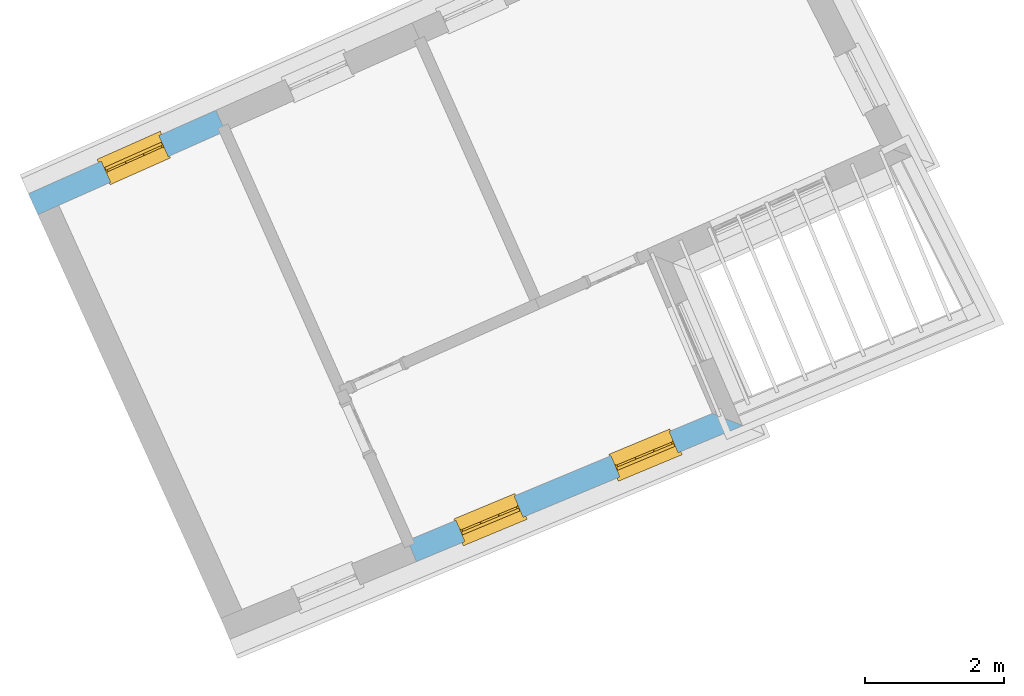
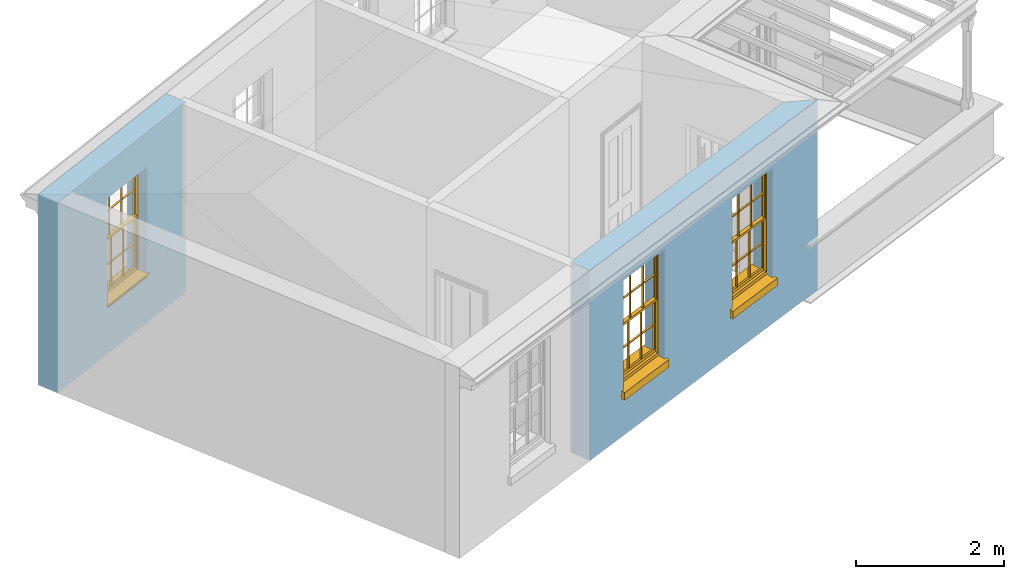
# One storey, part 3 of 10: 3 windows, 3 openings, plus 2 elements that do not belong to this part.
"""IFC2X3 building model written with IfcOpenShell, lengths in metres."""

from ifc_helpers import new_model, si_unit, frame, origin, place, context, subcontext, project, spatial, polyline, outline, extrude, faceted_brep, material, layer, layer_set, layer_usage, element, fill, save


model = new_model("IFC2X3")

# Units and contexts
model_context = context("Model", 3, world=origin())
body_context = subcontext(model_context, "Body", "Model", "MODEL_VIEW")
ifc_project = project(units=[si_unit("PLANEANGLEUNIT", "RADIAN"), si_unit("MASSUNIT", "GRAM", prefix="KILO"), si_unit("FORCEUNIT", "NEWTON", prefix="KILO"), si_unit("LENGTHUNIT", "METRE")], contexts=[model_context])

# Site, building, storey
site_placement = place(None, origin())
site = spatial("IfcSite", under=ifc_project, at=site_placement, CompositionType="ELEMENT")
building_placement = place(None, origin())
building = spatial("IfcBuilding", under=site, at=building_placement, Name="Building plot-1", CompositionType="ELEMENT")
storey_placement = place(None, frame((0.0, 0.0, 8.45)))
storey = spatial("IfcBuildingStorey", under=building, at=storey_placement, Name="Floor 2", CompositionType="ELEMENT", Elevation=8.45)

# Wall, openings, windows
ifc_material = material(Name="Masonry")
ifc_layer = layer(ifc_material, 0.33, ventilated=False)
ifc_layer_set = layer_set([ifc_layer], Name="My Wall")
ifc_layer_usage = layer_usage(ifc_layer_set, "AXIS2", "NEGATIVE", 0.08)
wall_1_placement = place(storey_placement, origin())
wall_1 = element("IfcWallStandardCase", 1, at=wall_1_placement, inside=storey, material=ifc_layer_usage, Name="exterior", context=body_context, shape_type="SweptSolid", body=[
    extrude(outline(polyline([(24.2430798056257, 41.3933128508107), (24.3699915253352, 41.0886927342715), (29.0644458342875, 43.0445099541443), (28.6286616795671, 43.2204467376737), (24.2430798056257, 41.3933128508107)])), origin(), (0.0, 0.0, 1.0), 3.15),
])
opening_1_placement = place(storey_placement, frame((0.0, 0.0, 0.75)))
opening_1 = element("IfcOpeningElement", 2, at=opening_1_placement, cuts=wall_1, Name="Opening", ObjectType="Opening", context=body_context, shape_type="SweptSolid", body=[
    extrude(outline(polyline([(25.0651000110172, 41.378290855055), (25.9051130596556, 41.7282595366783), (25.7782013399461, 42.0328796532175), (24.9381882913076, 41.6829109715942), (25.0651000110172, 41.378290855055)])), origin(), (0.0, 0.0, 1.0), 1.82),
])
opening_2_placement = place(storey_placement, frame((0.0, 0.0, 0.75)))
opening_2 = element("IfcOpeningElement", 3, at=opening_2_placement, cuts=wall_1, Name="Opening", ObjectType="Opening", context=body_context, shape_type="SweptSolid", body=[
    extrude(outline(polyline([(27.2953300310195, 42.3074557782452), (28.135343079658, 42.6574244598685), (28.0084313599484, 42.9620445764077), (27.16841831131, 42.6120758947844), (27.2953300310195, 42.3074557782452)])), origin(), (0.0, 0.0, 1.0), 1.82),
])
window_1_placement = place(storey_placement, frame((24.968954768813, 41.609063670615, 0.75), z_axis=(0.0, 0.0, 1.0), x_axis=(0.84001304863844, 0.349968681623302, 0.0)))
window_1 = element("IfcWindow", 4, at=window_1_placement, inside=storey, Name="circulation outside window", OverallHeight=1.82, OverallWidth=0.91, context=body_context, shape_type="Brep", held_by="IfcProductRepresentation", body=[
    faceted_brep([(0.033125, -0.105, 0.975209), (0.01, -0.105, 0.975209), (0.033125, -0.105, 1.376042), (0.876875, -0.105, 0.975209), (0.876875, -0.105, 1.376042), (0.9, -0.105, 0.975209), (0.876875, -0.105, 1.386042), (0.876875, -0.105, 1.786875), (0.9, -0.105, 1.81), (0.033125, -0.105, 1.786875), (0.033125, -0.105, 1.386042), (0.01, -0.105, 1.81), (0.876875, -0.135, 1.376042), (0.876875, -0.135, 0.975209), (0.9, -0.135, 0.937083), (0.033125, -0.135, 1.786875), (0.01, -0.135, 1.81), (0.033125, -0.135, 1.386042), (0.01, -0.135, 0.937083), (0.033125, -0.135, 0.975209), (0.033125, -0.135, 1.376042), (0.876875, -0.135, 1.786875), (0.876875, -0.135, 1.386042), (0.9, -0.135, 1.81), (0.033125, -0.105, 0.937083), (0.01, -0.105, 0.937083), (0.033125, -0.105, 0.53625), (0.876875, -0.105, 0.937083), (0.876875, -0.105, 0.53625), (0.9, -0.105, 0.937083), (0.876875, -0.105, 0.52625), (0.876875, -0.105, 0.125417), (0.9, -0.105, 0.077167), (0.033125, -0.105, 0.125417), (0.033125, -0.105, 0.52625), (0.01, -0.105, 0.077167), (-0.0425, -0.25, 0.01), (-0.0425, -0.3, 0.001667), (0.0, -0.25, 0.01), (0.9525, -0.25, 0.01), (0.91, -0.25, 0.01), (0.9525, -0.3, 0.001667), (-0.02, 0.08, 0.077167), (0.0, 0.08, 0.077167), (-0.02, 0.11, 0.077167), (0.0, -0.06, 0.077167), (0.01, -0.06, 0.077167), (0.91, -0.06, 0.077167), (0.91, 0.08, 0.077167), (0.9, -0.06, 0.077167), (0.93, 0.08, 0.077167), (0.93, 0.11, 0.077167), (0.01, -0.075, 0.975209), (0.9, -0.075, 0.975209), (0.876875, -0.075, 0.125417), (0.876875, -0.075, 0.52625), (0.9, -0.075, 0.077167), (0.876875, -0.075, 0.53625), (0.876875, -0.075, 0.937083), (0.033125, -0.075, 0.125417), (0.01, -0.075, 0.077167), (0.033125, -0.075, 0.52625), (0.033125, -0.075, 0.937083), (0.033125, -0.075, 0.53625), (-0.02, 0.08, 0.052167), (-0.02, 0.11, 0.052167), (0.93, 0.11, 0.052167), (0.93, 0.08, 0.052167), (0.91, 0.08, 0.052167), (0.0, 0.08, 0.052167), (0.91, -0.15, 0.026667), (0.0, -0.15, 0.026667), (-0.0425, -0.3, -0.123333), (0.9525, -0.3, -0.123333), (-0.0425, -0.25, -0.123333), (0.9525, -0.25, -0.123333), (0.01, -0.06, 1.81), (0.9, -0.06, 1.81), (0.0, -0.06, 1.82), (0.91, -0.06, 1.82), (0.01, -0.15, 0.077167), (0.9, -0.15, 0.077167), (0.592292, -0.105, 0.125417), (0.592292, -0.075, 0.125417), (0.317708, -0.075, 0.125417), (0.317708, -0.105, 0.125417), (0.592292, -0.105, 0.53625), (0.317708, -0.105, 0.53625), (0.317708, -0.105, 0.52625), (0.592292, -0.105, 0.52625), (0.592292, -0.075, 0.53625), (0.317708, -0.075, 0.53625), (0.592292, -0.135, 1.386042), (0.592292, -0.105, 1.386042), (0.317708, -0.105, 1.386042), (0.317708, -0.135, 1.386042), (0.317708, -0.135, 1.376042), (0.592292, -0.135, 1.376042), (0.317708, -0.105, 1.376042), (0.592292, -0.105, 1.376042), (0.602292, -0.135, 1.376042), (0.592292, -0.135, 0.975209), (0.602292, -0.135, 0.975209), (0.602292, -0.105, 0.975209), (0.592292, -0.105, 0.975209), (0.602292, -0.105, 1.376042), (0.602292, -0.075, 0.53625), (0.602292, -0.105, 0.53625), (0.317708, -0.075, 0.52625), (0.307708, -0.075, 0.125417), (0.307708, -0.075, 0.52625), (0.602292, -0.075, 0.52625), (0.602292, -0.075, 0.125417), (0.592292, -0.075, 0.52625), (0.307708, -0.075, 0.53625), (0.317708, -0.075, 0.937083), (0.307708, -0.075, 0.937083), (0.602292, -0.075, 0.937083), (0.592292, -0.075, 0.937083), (0.307708, -0.105, 0.52625), (0.307708, -0.105, 0.125417), (0.307708, -0.105, 0.53625), (0.307708, -0.105, 0.937083), (0.592292, -0.105, 0.937083), (0.317708, -0.105, 0.937083), (0.602292, -0.105, 0.937083), (0.602292, -0.105, 0.52625), (0.602292, -0.105, 0.125417), (0.307708, -0.135, 1.386042), (0.307708, -0.135, 1.376042), (0.307708, -0.135, 0.975209), (0.317708, -0.135, 0.975209), (0.317708, -0.135, 1.786875), (0.307708, -0.135, 1.786875), (0.602292, -0.135, 1.786875), (0.592292, -0.135, 1.786875), (0.602292, -0.135, 1.386042), (0.602292, -0.105, 1.386042), (0.307708, -0.105, 1.386042), (0.307708, -0.105, 1.786875), (0.317708, -0.105, 1.786875), (0.592292, -0.105, 1.786875), (0.602292, -0.105, 1.786875), (0.307708, -0.105, 1.376042), (0.317708, -0.105, 0.975209), (0.307708, -0.105, 0.975209), (0.91, -0.15, 1.82), (0.9, -0.15, 1.81), (0.01, -0.15, 1.81), (0.0, -0.15, 1.82), (0.91, -0.25, 0.0), (0.0, -0.25, 0.0), (0.91, 0.08, 0.0), (0.0, 0.08, 0.0)], [[[0, 1, 2]], [[3, 4, 5]], [[6, 7, 8]], [[9, 10, 11]], [[12, 13, 14]], [[15, 16, 17]], [[18, 19, 20]], [[21, 22, 23]], [[24, 25, 26]], [[27, 28, 29]], [[30, 31, 32]], [[33, 34, 35]], [[14, 27, 29]], [[25, 24, 18]], [[36, 37, 38]], [[39, 40, 41]], [[42, 43, 44]], [[45, 46, 43]], [[47, 48, 49]], [[50, 51, 48]], [[1, 0, 52]], [[5, 53, 3]], [[54, 55, 56]], [[57, 58, 53]], [[59, 60, 61]], [[62, 63, 52]], [[48, 43, 46, 49]], [[51, 44, 43, 48]], [[64, 42, 44, 65]], [[65, 44, 51, 66]], [[66, 51, 50, 67]], [[65, 66, 68, 69]], [[60, 56, 49, 46]], [[70, 71, 38, 40]], [[37, 41, 40, 38]], [[37, 72, 73, 41]], [[74, 75, 73, 72]], [[8, 11, 76, 77]], [[76, 78, 79, 77]], [[32, 35, 80, 81]], [[81, 80, 71, 70]], [[82, 83, 84, 85]], [[86, 87, 88, 89]], [[86, 90, 91, 87]], [[92, 93, 94, 95]], [[92, 95, 96, 97]], [[96, 98, 99, 97]], [[100, 97, 101, 102]], [[103, 104, 99, 105]], [[97, 99, 104, 101]], [[102, 103, 105, 100]], [[28, 57, 106, 107]], [[108, 84, 109, 110]], [[111, 112, 83, 113]], [[114, 110, 61, 63]], [[90, 113, 108, 91]], [[115, 91, 114, 116]], [[117, 106, 90, 118]], [[111, 106, 57, 55]], [[119, 110, 109, 120]], [[34, 61, 110, 119]], [[89, 113, 83, 82]], [[88, 108, 113, 89]], [[85, 84, 108, 88]], [[121, 114, 63, 26]], [[122, 116, 114, 121]], [[123, 118, 90, 86]], [[87, 91, 115, 124]], [[107, 106, 117, 125]], [[126, 111, 55, 30]], [[127, 112, 111, 126]], [[126, 30, 28, 107]], [[88, 119, 120, 85]], [[126, 89, 82, 127]], [[125, 123, 86, 107]], [[121, 26, 34, 119]], [[124, 122, 121, 87]], [[128, 17, 20, 129]], [[96, 129, 130, 131]], [[132, 133, 128, 95]], [[134, 135, 92, 136]], [[100, 12, 22, 136]], [[137, 6, 4, 105]], [[94, 138, 139, 140]], [[137, 93, 141, 142]], [[99, 98, 94, 93]], [[143, 2, 10, 138]], [[144, 145, 143, 98]], [[129, 143, 145, 130]], [[20, 2, 143, 129]], [[131, 144, 98, 96]], [[128, 138, 10, 17]], [[133, 139, 138, 128]], [[135, 141, 93, 92]], [[95, 94, 140, 132]], [[22, 6, 137, 136]], [[136, 137, 142, 134]], [[100, 105, 4, 12]], [[107, 86, 89, 126]], [[106, 111, 113, 90]], [[91, 108, 110, 114]], [[87, 121, 119, 88]], [[97, 100, 136, 92]], [[129, 96, 95, 128]], [[98, 143, 138, 94]], [[105, 99, 93, 137]], [[131, 101, 104, 144]], [[124, 115, 118, 123]], [[132, 140, 141, 135]], [[120, 109, 59, 33]], [[15, 9, 139, 133]], [[134, 142, 7, 21]], [[31, 54, 112, 127]], [[36, 74, 72, 37]], [[39, 41, 73, 75]], [[18, 14, 101, 131]], [[23, 16, 132, 135]], [[83, 56, 60, 84]], [[52, 53, 118, 115]], [[53, 52, 144, 104]], [[11, 8, 141, 140]], [[14, 18, 124, 123]], [[2, 1, 11, 10]], [[8, 5, 4, 6]], [[57, 53, 56, 55]], [[60, 52, 63, 61]], [[26, 25, 35, 34]], [[32, 29, 28, 30]], [[14, 23, 22, 12]], [[18, 20, 17, 16]], [[19, 0, 2, 20]], [[17, 10, 9, 15]], [[12, 4, 3, 13]], [[21, 7, 6, 22]], [[27, 58, 57, 28]], [[30, 55, 54, 31]], [[33, 59, 61, 34]], [[26, 63, 62, 24]], [[5, 8, 77, 53]], [[76, 11, 1, 52]], [[46, 45, 78, 76]], [[49, 77, 79, 47]], [[70, 146, 147, 81]], [[71, 80, 148, 149]], [[19, 130, 145, 0]], [[102, 13, 3, 103]], [[116, 122, 24, 62]], [[29, 32, 81, 14]], [[80, 35, 25, 18]], [[60, 46, 76, 52]], [[77, 49, 56, 53]], [[23, 14, 81, 147]], [[16, 148, 80, 18]], [[35, 85, 120]], [[120, 33, 35]], [[127, 82, 32]], [[32, 31, 127]], [[32, 82, 85, 35]], [[102, 101, 14]], [[14, 13, 102]], [[18, 131, 130]], [[130, 19, 18]], [[134, 21, 23]], [[23, 135, 134]], [[16, 15, 133]], [[133, 132, 16]], [[11, 140, 139]], [[139, 9, 11]], [[142, 141, 8]], [[8, 7, 142]], [[23, 147, 148, 16]], [[146, 149, 148, 147]], [[52, 115, 116]], [[116, 62, 52]], [[118, 53, 117]], [[58, 117, 53]], [[27, 125, 117, 58]], [[56, 83, 112]], [[112, 54, 56]], [[109, 84, 60]], [[60, 59, 109]], [[125, 27, 14]], [[14, 123, 125]], [[122, 124, 18]], [[18, 24, 122]], [[145, 144, 52]], [[52, 0, 145]], [[103, 3, 53]], [[53, 104, 103]], [[79, 78, 149, 146]], [[78, 45, 71, 149]], [[146, 70, 47, 79]], [[150, 75, 74, 151]], [[68, 66, 67]], [[48, 68, 67, 50]], [[69, 64, 65]], [[42, 64, 69, 43]], [[69, 68, 152, 153]], [[70, 68, 48, 47]], [[150, 152, 68, 70]], [[43, 69, 71, 45]], [[69, 153, 151, 71]], [[152, 150, 151, 153]], [[38, 151, 74, 36]], [[71, 151, 38]], [[39, 75, 150, 40]], [[40, 150, 70]]]),
])
fill(opening_1, window_1)
window_2_placement = place(storey_placement, frame((27.1991847888153, 42.5382285938052, 0.75), z_axis=(0.0, 0.0, 1.0), x_axis=(0.84001304863844, 0.349968681623302, 0.0)))
window_2 = element("IfcWindow", 5, at=window_2_placement, inside=storey, Name="circulation outside window", OverallHeight=1.82, OverallWidth=0.91, context=body_context, shape_type="Brep", held_by="IfcProductRepresentation", body=[
    faceted_brep([(0.033125, -0.105, 0.975209), (0.01, -0.105, 0.975209), (0.033125, -0.105, 1.376042), (0.876875, -0.105, 0.975209), (0.876875, -0.105, 1.376042), (0.9, -0.105, 0.975209), (0.876875, -0.105, 1.386042), (0.876875, -0.105, 1.786875), (0.9, -0.105, 1.81), (0.033125, -0.105, 1.786875), (0.033125, -0.105, 1.386042), (0.01, -0.105, 1.81), (0.876875, -0.135, 1.376042), (0.876875, -0.135, 0.975209), (0.9, -0.135, 0.937083), (0.033125, -0.135, 1.786875), (0.01, -0.135, 1.81), (0.033125, -0.135, 1.386042), (0.01, -0.135, 0.937083), (0.033125, -0.135, 0.975209), (0.033125, -0.135, 1.376042), (0.876875, -0.135, 1.786875), (0.876875, -0.135, 1.386042), (0.9, -0.135, 1.81), (0.033125, -0.105, 0.937083), (0.01, -0.105, 0.937083), (0.033125, -0.105, 0.53625), (0.876875, -0.105, 0.937083), (0.876875, -0.105, 0.53625), (0.9, -0.105, 0.937083), (0.876875, -0.105, 0.52625), (0.876875, -0.105, 0.125417), (0.9, -0.105, 0.077167), (0.033125, -0.105, 0.125417), (0.033125, -0.105, 0.52625), (0.01, -0.105, 0.077167), (-0.0425, -0.25, 0.01), (-0.0425, -0.3, 0.001667), (0.0, -0.25, 0.01), (0.9525, -0.25, 0.01), (0.91, -0.25, 0.01), (0.9525, -0.3, 0.001667), (-0.02, 0.08, 0.077167), (0.0, 0.08, 0.077167), (-0.02, 0.11, 0.077167), (0.0, -0.06, 0.077167), (0.01, -0.06, 0.077167), (0.91, -0.06, 0.077167), (0.91, 0.08, 0.077167), (0.9, -0.06, 0.077167), (0.93, 0.08, 0.077167), (0.93, 0.11, 0.077167), (0.01, -0.075, 0.975209), (0.9, -0.075, 0.975209), (0.876875, -0.075, 0.125417), (0.876875, -0.075, 0.52625), (0.9, -0.075, 0.077167), (0.876875, -0.075, 0.53625), (0.876875, -0.075, 0.937083), (0.033125, -0.075, 0.125417), (0.01, -0.075, 0.077167), (0.033125, -0.075, 0.52625), (0.033125, -0.075, 0.937083), (0.033125, -0.075, 0.53625), (-0.02, 0.08, 0.052167), (-0.02, 0.11, 0.052167), (0.93, 0.11, 0.052167), (0.93, 0.08, 0.052167), (0.91, 0.08, 0.052167), (0.0, 0.08, 0.052167), (0.91, -0.15, 0.026667), (0.0, -0.15, 0.026667), (-0.0425, -0.3, -0.123333), (0.9525, -0.3, -0.123333), (-0.0425, -0.25, -0.123333), (0.9525, -0.25, -0.123333), (0.01, -0.06, 1.81), (0.9, -0.06, 1.81), (0.0, -0.06, 1.82), (0.91, -0.06, 1.82), (0.01, -0.15, 0.077167), (0.9, -0.15, 0.077167), (0.592292, -0.105, 0.125417), (0.592292, -0.075, 0.125417), (0.317708, -0.075, 0.125417), (0.317708, -0.105, 0.125417), (0.592292, -0.105, 0.53625), (0.317708, -0.105, 0.53625), (0.317708, -0.105, 0.52625), (0.592292, -0.105, 0.52625), (0.592292, -0.075, 0.53625), (0.317708, -0.075, 0.53625), (0.592292, -0.135, 1.386042), (0.592292, -0.105, 1.386042), (0.317708, -0.105, 1.386042), (0.317708, -0.135, 1.386042), (0.317708, -0.135, 1.376042), (0.592292, -0.135, 1.376042), (0.317708, -0.105, 1.376042), (0.592292, -0.105, 1.376042), (0.602292, -0.135, 1.376042), (0.592292, -0.135, 0.975209), (0.602292, -0.135, 0.975209), (0.602292, -0.105, 0.975209), (0.592292, -0.105, 0.975209), (0.602292, -0.105, 1.376042), (0.602292, -0.075, 0.53625), (0.602292, -0.105, 0.53625), (0.317708, -0.075, 0.52625), (0.307708, -0.075, 0.125417), (0.307708, -0.075, 0.52625), (0.602292, -0.075, 0.52625), (0.602292, -0.075, 0.125417), (0.592292, -0.075, 0.52625), (0.307708, -0.075, 0.53625), (0.317708, -0.075, 0.937083), (0.307708, -0.075, 0.937083), (0.602292, -0.075, 0.937083), (0.592292, -0.075, 0.937083), (0.307708, -0.105, 0.52625), (0.307708, -0.105, 0.125417), (0.307708, -0.105, 0.53625), (0.307708, -0.105, 0.937083), (0.592292, -0.105, 0.937083), (0.317708, -0.105, 0.937083), (0.602292, -0.105, 0.937083), (0.602292, -0.105, 0.52625), (0.602292, -0.105, 0.125417), (0.307708, -0.135, 1.386042), (0.307708, -0.135, 1.376042), (0.307708, -0.135, 0.975209), (0.317708, -0.135, 0.975209), (0.317708, -0.135, 1.786875), (0.307708, -0.135, 1.786875), (0.602292, -0.135, 1.786875), (0.592292, -0.135, 1.786875), (0.602292, -0.135, 1.386042), (0.602292, -0.105, 1.386042), (0.307708, -0.105, 1.386042), (0.307708, -0.105, 1.786875), (0.317708, -0.105, 1.786875), (0.592292, -0.105, 1.786875), (0.602292, -0.105, 1.786875), (0.307708, -0.105, 1.376042), (0.317708, -0.105, 0.975209), (0.307708, -0.105, 0.975209), (0.91, -0.15, 1.82), (0.9, -0.15, 1.81), (0.01, -0.15, 1.81), (0.0, -0.15, 1.82), (0.91, -0.25, 0.0), (0.0, -0.25, 0.0), (0.91, 0.08, 0.0), (0.0, 0.08, 0.0)], [[[0, 1, 2]], [[3, 4, 5]], [[6, 7, 8]], [[9, 10, 11]], [[12, 13, 14]], [[15, 16, 17]], [[18, 19, 20]], [[21, 22, 23]], [[24, 25, 26]], [[27, 28, 29]], [[30, 31, 32]], [[33, 34, 35]], [[14, 27, 29]], [[25, 24, 18]], [[36, 37, 38]], [[39, 40, 41]], [[42, 43, 44]], [[45, 46, 43]], [[47, 48, 49]], [[50, 51, 48]], [[1, 0, 52]], [[5, 53, 3]], [[54, 55, 56]], [[57, 58, 53]], [[59, 60, 61]], [[62, 63, 52]], [[48, 43, 46, 49]], [[51, 44, 43, 48]], [[64, 42, 44, 65]], [[65, 44, 51, 66]], [[66, 51, 50, 67]], [[65, 66, 68, 69]], [[60, 56, 49, 46]], [[70, 71, 38, 40]], [[37, 41, 40, 38]], [[37, 72, 73, 41]], [[74, 75, 73, 72]], [[8, 11, 76, 77]], [[76, 78, 79, 77]], [[32, 35, 80, 81]], [[81, 80, 71, 70]], [[82, 83, 84, 85]], [[86, 87, 88, 89]], [[86, 90, 91, 87]], [[92, 93, 94, 95]], [[92, 95, 96, 97]], [[96, 98, 99, 97]], [[100, 97, 101, 102]], [[103, 104, 99, 105]], [[97, 99, 104, 101]], [[102, 103, 105, 100]], [[28, 57, 106, 107]], [[108, 84, 109, 110]], [[111, 112, 83, 113]], [[114, 110, 61, 63]], [[90, 113, 108, 91]], [[115, 91, 114, 116]], [[117, 106, 90, 118]], [[111, 106, 57, 55]], [[119, 110, 109, 120]], [[34, 61, 110, 119]], [[89, 113, 83, 82]], [[88, 108, 113, 89]], [[85, 84, 108, 88]], [[121, 114, 63, 26]], [[122, 116, 114, 121]], [[123, 118, 90, 86]], [[87, 91, 115, 124]], [[107, 106, 117, 125]], [[126, 111, 55, 30]], [[127, 112, 111, 126]], [[126, 30, 28, 107]], [[88, 119, 120, 85]], [[126, 89, 82, 127]], [[125, 123, 86, 107]], [[121, 26, 34, 119]], [[124, 122, 121, 87]], [[128, 17, 20, 129]], [[96, 129, 130, 131]], [[132, 133, 128, 95]], [[134, 135, 92, 136]], [[100, 12, 22, 136]], [[137, 6, 4, 105]], [[94, 138, 139, 140]], [[137, 93, 141, 142]], [[99, 98, 94, 93]], [[143, 2, 10, 138]], [[144, 145, 143, 98]], [[129, 143, 145, 130]], [[20, 2, 143, 129]], [[131, 144, 98, 96]], [[128, 138, 10, 17]], [[133, 139, 138, 128]], [[135, 141, 93, 92]], [[95, 94, 140, 132]], [[22, 6, 137, 136]], [[136, 137, 142, 134]], [[100, 105, 4, 12]], [[107, 86, 89, 126]], [[106, 111, 113, 90]], [[91, 108, 110, 114]], [[87, 121, 119, 88]], [[97, 100, 136, 92]], [[129, 96, 95, 128]], [[98, 143, 138, 94]], [[105, 99, 93, 137]], [[131, 101, 104, 144]], [[124, 115, 118, 123]], [[132, 140, 141, 135]], [[120, 109, 59, 33]], [[15, 9, 139, 133]], [[134, 142, 7, 21]], [[31, 54, 112, 127]], [[36, 74, 72, 37]], [[39, 41, 73, 75]], [[18, 14, 101, 131]], [[23, 16, 132, 135]], [[83, 56, 60, 84]], [[52, 53, 118, 115]], [[53, 52, 144, 104]], [[11, 8, 141, 140]], [[14, 18, 124, 123]], [[2, 1, 11, 10]], [[8, 5, 4, 6]], [[57, 53, 56, 55]], [[60, 52, 63, 61]], [[26, 25, 35, 34]], [[32, 29, 28, 30]], [[14, 23, 22, 12]], [[18, 20, 17, 16]], [[19, 0, 2, 20]], [[17, 10, 9, 15]], [[12, 4, 3, 13]], [[21, 7, 6, 22]], [[27, 58, 57, 28]], [[30, 55, 54, 31]], [[33, 59, 61, 34]], [[26, 63, 62, 24]], [[5, 8, 77, 53]], [[76, 11, 1, 52]], [[46, 45, 78, 76]], [[49, 77, 79, 47]], [[70, 146, 147, 81]], [[71, 80, 148, 149]], [[19, 130, 145, 0]], [[102, 13, 3, 103]], [[116, 122, 24, 62]], [[29, 32, 81, 14]], [[80, 35, 25, 18]], [[60, 46, 76, 52]], [[77, 49, 56, 53]], [[23, 14, 81, 147]], [[16, 148, 80, 18]], [[35, 85, 120]], [[120, 33, 35]], [[127, 82, 32]], [[32, 31, 127]], [[32, 82, 85, 35]], [[102, 101, 14]], [[14, 13, 102]], [[18, 131, 130]], [[130, 19, 18]], [[134, 21, 23]], [[23, 135, 134]], [[16, 15, 133]], [[133, 132, 16]], [[11, 140, 139]], [[139, 9, 11]], [[142, 141, 8]], [[8, 7, 142]], [[23, 147, 148, 16]], [[146, 149, 148, 147]], [[52, 115, 116]], [[116, 62, 52]], [[118, 53, 117]], [[58, 117, 53]], [[27, 125, 117, 58]], [[56, 83, 112]], [[112, 54, 56]], [[109, 84, 60]], [[60, 59, 109]], [[125, 27, 14]], [[14, 123, 125]], [[122, 124, 18]], [[18, 24, 122]], [[145, 144, 52]], [[52, 0, 145]], [[103, 3, 53]], [[53, 104, 103]], [[79, 78, 149, 146]], [[78, 45, 71, 149]], [[146, 70, 47, 79]], [[150, 75, 74, 151]], [[68, 66, 67]], [[48, 68, 67, 50]], [[69, 64, 65]], [[42, 64, 69, 43]], [[69, 68, 152, 153]], [[70, 68, 48, 47]], [[150, 152, 68, 70]], [[43, 69, 71, 45]], [[69, 153, 151, 71]], [[152, 150, 151, 153]], [[38, 151, 74, 36]], [[71, 151, 38]], [[39, 75, 150, 40]], [[40, 150, 70]]]),
])
fill(opening_2, window_2)

# Wall, opening, window
wall_2_placement = place(storey_placement, origin())
wall_2 = element("IfcWallStandardCase", 6, at=wall_2_placement, inside=storey, material=ifc_layer_usage, Name="exterior", context=body_context, shape_type="SweptSolid", body=[
    extrude(outline(polyline([(21.6184925194357, 47.2817904729088), (21.4842375416494, 47.5832462755393), (18.7880965575994, 46.3825052555824), (18.9223515353857, 46.0810494529519), (21.6184925194357, 47.2817904729088)])), origin(), (0.0, 0.0, 1.0), 3.15),
])
opening_3_placement = place(storey_placement, frame((0.0, 0.0, 0.75)))
opening_3 = element("IfcOpeningElement", 7, at=opening_3_placement, cuts=wall_2, Name="Opening", ObjectType="Opening", context=body_context, shape_type="SweptSolid", body=[
    extrude(outline(polyline([(20.6659984603083, 47.218839059852), (19.8347112469939, 46.8486207877745), (19.9689662247802, 46.547164985144), (20.8002534380946, 46.9173832572215), (20.6659984603083, 47.218839059852)])), origin(), (0.0, 0.0, 1.0), 1.82),
])
window_3_placement = place(storey_placement, frame((20.7677067768131, 46.9904634517986, 0.75), z_axis=(0.0, 0.0, 1.0), x_axis=(-0.831287213314376, -0.370218272077466, 0.0)))
window_3 = element("IfcWindow", 8, at=window_3_placement, inside=storey, Name="bedroom outside window", OverallHeight=1.82, OverallWidth=0.91, context=body_context, shape_type="Brep", held_by="IfcProductRepresentation", body=[
    faceted_brep([(0.033125, -0.105, 0.975209), (0.01, -0.105, 0.975209), (0.033125, -0.105, 1.376042), (0.876875, -0.105, 0.975209), (0.876875, -0.105, 1.376042), (0.9, -0.105, 0.975209), (0.876875, -0.105, 1.386042), (0.876875, -0.105, 1.786875), (0.9, -0.105, 1.81), (0.033125, -0.105, 1.786875), (0.033125, -0.105, 1.386042), (0.01, -0.105, 1.81), (0.876875, -0.135, 1.376042), (0.876875, -0.135, 0.975209), (0.9, -0.135, 0.937083), (0.033125, -0.135, 1.786875), (0.01, -0.135, 1.81), (0.033125, -0.135, 1.386042), (0.01, -0.135, 0.937083), (0.033125, -0.135, 0.975209), (0.033125, -0.135, 1.376042), (0.876875, -0.135, 1.786875), (0.876875, -0.135, 1.386042), (0.9, -0.135, 1.81), (0.033125, -0.105, 0.937083), (0.01, -0.105, 0.937083), (0.033125, -0.105, 0.53625), (0.876875, -0.105, 0.937083), (0.876875, -0.105, 0.53625), (0.9, -0.105, 0.937083), (0.876875, -0.105, 0.52625), (0.876875, -0.105, 0.125417), (0.9, -0.105, 0.077167), (0.033125, -0.105, 0.125417), (0.033125, -0.105, 0.52625), (0.01, -0.105, 0.077167), (-0.0425, -0.25, 0.01), (-0.0425, -0.3, 0.001667), (0.0, -0.25, 0.01), (0.9525, -0.25, 0.01), (0.91, -0.25, 0.01), (0.9525, -0.3, 0.001667), (-0.02, 0.08, 0.077167), (0.0, 0.08, 0.077167), (-0.02, 0.11, 0.077167), (0.0, -0.06, 0.077167), (0.01, -0.06, 0.077167), (0.91, -0.06, 0.077167), (0.91, 0.08, 0.077167), (0.9, -0.06, 0.077167), (0.93, 0.08, 0.077167), (0.93, 0.11, 0.077167), (0.01, -0.075, 0.975209), (0.9, -0.075, 0.975209), (0.876875, -0.075, 0.125417), (0.876875, -0.075, 0.52625), (0.9, -0.075, 0.077167), (0.876875, -0.075, 0.53625), (0.876875, -0.075, 0.937083), (0.033125, -0.075, 0.125417), (0.01, -0.075, 0.077167), (0.033125, -0.075, 0.52625), (0.033125, -0.075, 0.937083), (0.033125, -0.075, 0.53625), (-0.02, 0.08, 0.052167), (-0.02, 0.11, 0.052167), (0.93, 0.11, 0.052167), (0.93, 0.08, 0.052167), (0.91, 0.08, 0.052167), (0.0, 0.08, 0.052167), (0.91, -0.15, 0.026667), (0.0, -0.15, 0.026667), (-0.0425, -0.3, -0.123333), (0.9525, -0.3, -0.123333), (-0.0425, -0.25, -0.123333), (0.9525, -0.25, -0.123333), (0.01, -0.06, 1.81), (0.9, -0.06, 1.81), (0.0, -0.06, 1.82), (0.91, -0.06, 1.82), (0.01, -0.15, 0.077167), (0.9, -0.15, 0.077167), (0.592292, -0.105, 0.125417), (0.592292, -0.075, 0.125417), (0.317708, -0.075, 0.125417), (0.317708, -0.105, 0.125417), (0.592292, -0.105, 0.53625), (0.317708, -0.105, 0.53625), (0.317708, -0.105, 0.52625), (0.592292, -0.105, 0.52625), (0.592292, -0.075, 0.53625), (0.317708, -0.075, 0.53625), (0.592292, -0.135, 1.386042), (0.592292, -0.105, 1.386042), (0.317708, -0.105, 1.386042), (0.317708, -0.135, 1.386042), (0.317708, -0.135, 1.376042), (0.592292, -0.135, 1.376042), (0.317708, -0.105, 1.376042), (0.592292, -0.105, 1.376042), (0.602292, -0.135, 1.376042), (0.592292, -0.135, 0.975209), (0.602292, -0.135, 0.975209), (0.602292, -0.105, 0.975209), (0.592292, -0.105, 0.975209), (0.602292, -0.105, 1.376042), (0.602292, -0.075, 0.53625), (0.602292, -0.105, 0.53625), (0.317708, -0.075, 0.52625), (0.307708, -0.075, 0.125417), (0.307708, -0.075, 0.52625), (0.602292, -0.075, 0.52625), (0.602292, -0.075, 0.125417), (0.592292, -0.075, 0.52625), (0.307708, -0.075, 0.53625), (0.317708, -0.075, 0.937083), (0.307708, -0.075, 0.937083), (0.602292, -0.075, 0.937083), (0.592292, -0.075, 0.937083), (0.307708, -0.105, 0.52625), (0.307708, -0.105, 0.125417), (0.307708, -0.105, 0.53625), (0.307708, -0.105, 0.937083), (0.592292, -0.105, 0.937083), (0.317708, -0.105, 0.937083), (0.602292, -0.105, 0.937083), (0.602292, -0.105, 0.52625), (0.602292, -0.105, 0.125417), (0.307708, -0.135, 1.386042), (0.307708, -0.135, 1.376042), (0.307708, -0.135, 0.975209), (0.317708, -0.135, 0.975209), (0.317708, -0.135, 1.786875), (0.307708, -0.135, 1.786875), (0.602292, -0.135, 1.786875), (0.592292, -0.135, 1.786875), (0.602292, -0.135, 1.386042), (0.602292, -0.105, 1.386042), (0.307708, -0.105, 1.386042), (0.307708, -0.105, 1.786875), (0.317708, -0.105, 1.786875), (0.592292, -0.105, 1.786875), (0.602292, -0.105, 1.786875), (0.307708, -0.105, 1.376042), (0.317708, -0.105, 0.975209), (0.307708, -0.105, 0.975209), (0.91, -0.15, 1.82), (0.9, -0.15, 1.81), (0.01, -0.15, 1.81), (0.0, -0.15, 1.82), (0.91, -0.25, 0.0), (0.0, -0.25, 0.0), (0.91, 0.08, 0.0), (0.0, 0.08, 0.0)], [[[0, 1, 2]], [[3, 4, 5]], [[6, 7, 8]], [[9, 10, 11]], [[12, 13, 14]], [[15, 16, 17]], [[18, 19, 20]], [[21, 22, 23]], [[24, 25, 26]], [[27, 28, 29]], [[30, 31, 32]], [[33, 34, 35]], [[14, 27, 29]], [[25, 24, 18]], [[36, 37, 38]], [[39, 40, 41]], [[42, 43, 44]], [[45, 46, 43]], [[47, 48, 49]], [[50, 51, 48]], [[1, 0, 52]], [[5, 53, 3]], [[54, 55, 56]], [[57, 58, 53]], [[59, 60, 61]], [[62, 63, 52]], [[48, 43, 46, 49]], [[51, 44, 43, 48]], [[64, 42, 44, 65]], [[65, 44, 51, 66]], [[66, 51, 50, 67]], [[65, 66, 68, 69]], [[60, 56, 49, 46]], [[70, 71, 38, 40]], [[37, 41, 40, 38]], [[37, 72, 73, 41]], [[74, 75, 73, 72]], [[8, 11, 76, 77]], [[76, 78, 79, 77]], [[32, 35, 80, 81]], [[81, 80, 71, 70]], [[82, 83, 84, 85]], [[86, 87, 88, 89]], [[86, 90, 91, 87]], [[92, 93, 94, 95]], [[92, 95, 96, 97]], [[96, 98, 99, 97]], [[100, 97, 101, 102]], [[103, 104, 99, 105]], [[97, 99, 104, 101]], [[102, 103, 105, 100]], [[28, 57, 106, 107]], [[108, 84, 109, 110]], [[111, 112, 83, 113]], [[114, 110, 61, 63]], [[90, 113, 108, 91]], [[115, 91, 114, 116]], [[117, 106, 90, 118]], [[111, 106, 57, 55]], [[119, 110, 109, 120]], [[34, 61, 110, 119]], [[89, 113, 83, 82]], [[88, 108, 113, 89]], [[85, 84, 108, 88]], [[121, 114, 63, 26]], [[122, 116, 114, 121]], [[123, 118, 90, 86]], [[87, 91, 115, 124]], [[107, 106, 117, 125]], [[126, 111, 55, 30]], [[127, 112, 111, 126]], [[126, 30, 28, 107]], [[88, 119, 120, 85]], [[126, 89, 82, 127]], [[125, 123, 86, 107]], [[121, 26, 34, 119]], [[124, 122, 121, 87]], [[128, 17, 20, 129]], [[96, 129, 130, 131]], [[132, 133, 128, 95]], [[134, 135, 92, 136]], [[100, 12, 22, 136]], [[137, 6, 4, 105]], [[94, 138, 139, 140]], [[137, 93, 141, 142]], [[99, 98, 94, 93]], [[143, 2, 10, 138]], [[144, 145, 143, 98]], [[129, 143, 145, 130]], [[20, 2, 143, 129]], [[131, 144, 98, 96]], [[128, 138, 10, 17]], [[133, 139, 138, 128]], [[135, 141, 93, 92]], [[95, 94, 140, 132]], [[22, 6, 137, 136]], [[136, 137, 142, 134]], [[100, 105, 4, 12]], [[107, 86, 89, 126]], [[106, 111, 113, 90]], [[91, 108, 110, 114]], [[87, 121, 119, 88]], [[97, 100, 136, 92]], [[129, 96, 95, 128]], [[98, 143, 138, 94]], [[105, 99, 93, 137]], [[131, 101, 104, 144]], [[124, 115, 118, 123]], [[132, 140, 141, 135]], [[120, 109, 59, 33]], [[15, 9, 139, 133]], [[134, 142, 7, 21]], [[31, 54, 112, 127]], [[36, 74, 72, 37]], [[39, 41, 73, 75]], [[18, 14, 101, 131]], [[23, 16, 132, 135]], [[83, 56, 60, 84]], [[52, 53, 118, 115]], [[53, 52, 144, 104]], [[11, 8, 141, 140]], [[14, 18, 124, 123]], [[2, 1, 11, 10]], [[8, 5, 4, 6]], [[57, 53, 56, 55]], [[60, 52, 63, 61]], [[26, 25, 35, 34]], [[32, 29, 28, 30]], [[14, 23, 22, 12]], [[18, 20, 17, 16]], [[19, 0, 2, 20]], [[17, 10, 9, 15]], [[12, 4, 3, 13]], [[21, 7, 6, 22]], [[27, 58, 57, 28]], [[30, 55, 54, 31]], [[33, 59, 61, 34]], [[26, 63, 62, 24]], [[5, 8, 77, 53]], [[76, 11, 1, 52]], [[46, 45, 78, 76]], [[49, 77, 79, 47]], [[70, 146, 147, 81]], [[71, 80, 148, 149]], [[19, 130, 145, 0]], [[102, 13, 3, 103]], [[116, 122, 24, 62]], [[29, 32, 81, 14]], [[80, 35, 25, 18]], [[60, 46, 76, 52]], [[77, 49, 56, 53]], [[23, 14, 81, 147]], [[16, 148, 80, 18]], [[35, 85, 120]], [[120, 33, 35]], [[127, 82, 32]], [[32, 31, 127]], [[32, 82, 85, 35]], [[102, 101, 14]], [[14, 13, 102]], [[18, 131, 130]], [[130, 19, 18]], [[134, 21, 23]], [[23, 135, 134]], [[16, 15, 133]], [[133, 132, 16]], [[11, 140, 139]], [[139, 9, 11]], [[142, 141, 8]], [[8, 7, 142]], [[23, 147, 148, 16]], [[146, 149, 148, 147]], [[52, 115, 116]], [[116, 62, 52]], [[118, 53, 117]], [[58, 117, 53]], [[27, 125, 117, 58]], [[56, 83, 112]], [[112, 54, 56]], [[109, 84, 60]], [[60, 59, 109]], [[125, 27, 14]], [[14, 123, 125]], [[122, 124, 18]], [[18, 24, 122]], [[145, 144, 52]], [[52, 0, 145]], [[103, 3, 53]], [[53, 104, 103]], [[79, 78, 149, 146]], [[78, 45, 71, 149]], [[146, 70, 47, 79]], [[150, 75, 74, 151]], [[68, 66, 67]], [[48, 68, 67, 50]], [[69, 64, 65]], [[42, 64, 69, 43]], [[69, 68, 152, 153]], [[70, 68, 48, 47]], [[150, 152, 68, 70]], [[43, 69, 71, 45]], [[69, 153, 151, 71]], [[152, 150, 151, 153]], [[38, 151, 74, 36]], [[71, 151, 38]], [[39, 75, 150, 40]], [[40, 150, 70]]]),
])
fill(opening_3, window_3)

save(model, "model.ifc")
